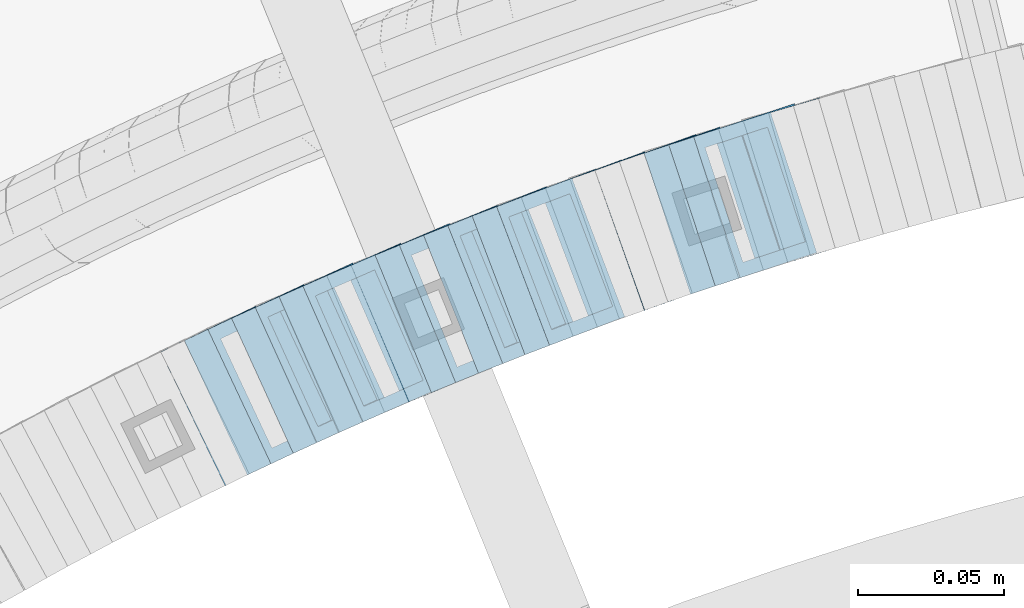
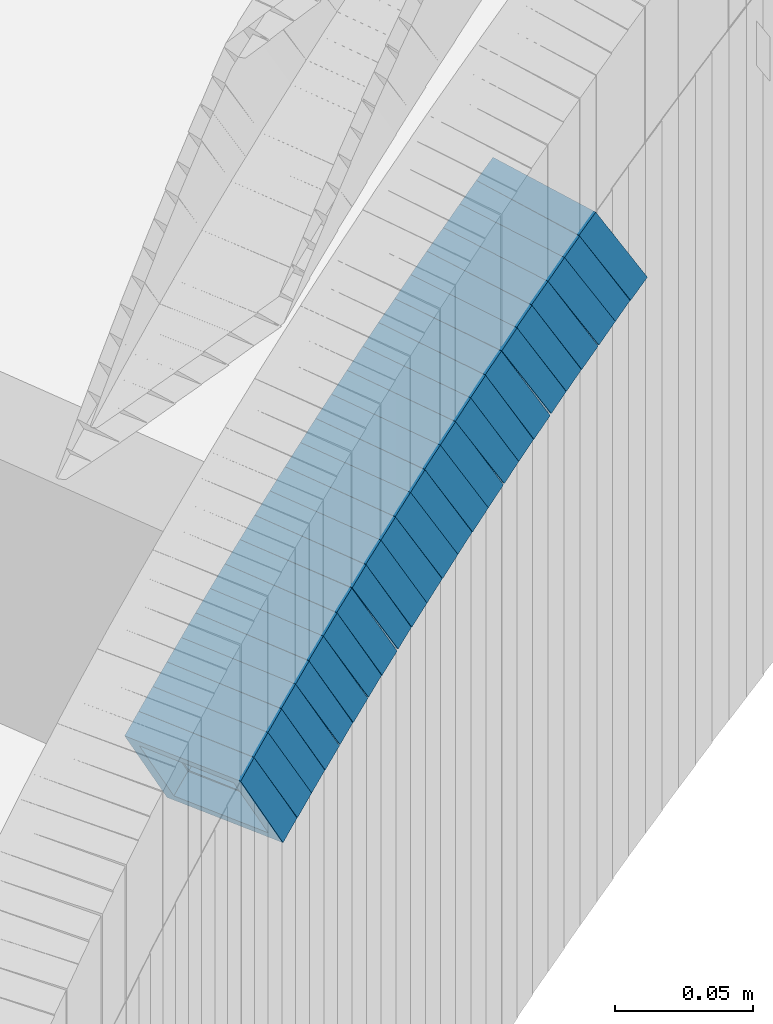
# One storey, part 747 of 975: 24 members.
"""IFC2X3 building model written with IfcOpenShell, lengths in millimetres."""

import ifcopenshell
import ifcopenshell.guid

model = None  # the IFC model being written
_history = None  # IfcOwnerHistory: only IFC2X3 demands one
_inside = {}  # id of a spatial element -> (the spatial element, [elements in it])
_under = {}  # id of a project, library or spatial element -> (it, [spatial elements below it])
_declared = {}  # id of a project -> (the project, [libraries it declares])
_typed = {}  # id of a type object -> (the type object, [elements of that type])
_made_of = {}  # id of a material, layer set ... -> (it, [elements and type objects made of it])


def new_model(schema):
    """Start an empty IFC model of exactly this schema.

    Asked for "IFC4X3", IfcOpenShell would pick the latest addendum, in which some entities
    have other attributes; the version numbers below select the first issue.
    IFC2X3 requires an IfcOwnerHistory on every rooted entity: one is made here for all.
    """
    global model, _history
    if schema == "IFC4X3":
        model = ifcopenshell.file(schema_version=(4, 3, 0, 0))
    else:
        model = ifcopenshell.file(schema=schema)
    _inside.clear()
    _under.clear()
    _declared.clear()
    _typed.clear()
    _made_of.clear()
    _history = None
    if model.schema == "IFC2X3":
        org = make("IfcOrganization", Name="unknown")
        user = make(
            "IfcPersonAndOrganization",
            ThePerson=make("IfcPerson", FamilyName="unknown"),
            TheOrganization=org,
        )
        app = make(
            "IfcApplication",
            ApplicationDeveloper=org,
            Version="unknown",
            ApplicationFullName="unknown",
            ApplicationIdentifier="unknown",
        )
        _history = make(
            "IfcOwnerHistory",
            OwningUser=user,
            OwningApplication=app,
            ChangeAction="ADDED",
            CreationDate=0,
        )
    return model


def make(cls, **values):
    """One entity of the class cls with the attributes given. An attribute that is None is left unset."""
    return model.create_entity(
        cls, **{name: value for name, value in values.items() if value is not None}
    )


def rooted(cls, **values):
    """An entity with a GlobalId (a new one), such as an element, a storey or a relation."""
    return make(cls, GlobalId=ifcopenshell.guid.new(), OwnerHistory=_history, **values)


def si_unit(unit_type, name, prefix=None):
    """IfcSIUnit, for example si_unit("LENGTHUNIT", "METRE", prefix="MILLI")."""
    return make("IfcSIUnit", UnitType=unit_type, Prefix=prefix, Name=name)


def assignment(units):
    """IfcUnitAssignment: the units of a project."""
    return None if units is None else make("IfcUnitAssignment", Units=units)


def point(xyz):
    """IfcCartesianPoint."""
    return None if xyz is None else make("IfcCartesianPoint", Coordinates=xyz)


def direction(xyz):
    """IfcDirection."""
    return None if xyz is None else make("IfcDirection", DirectionRatios=xyz)


def frame(location, z_axis=None, x_axis=None):
    """IfcAxis2Placement3D, a coordinate frame: its origin and axes. An axis left out is left unset."""
    return make(
        "IfcAxis2Placement3D",
        Location=point(location),
        Axis=direction(z_axis),
        RefDirection=direction(x_axis),
    )


def origin_with_axes():
    """The frame at (0, 0, 0) with the z axis (0, 0, 1) and the x axis (1, 0, 0) written out."""
    return frame((0.0, 0.0, 0.0), z_axis=(0.0, 0.0, 1.0), x_axis=(1.0, 0.0, 0.0))


def place(relative_to, where):
    """IfcLocalPlacement: puts the frame where relative to a parent placement (None: the world)."""
    return make(
        "IfcLocalPlacement", PlacementRelTo=relative_to, RelativePlacement=where
    )


def context(
    kind, dimensions, precision=None, world=None, true_north=None, identifier=None
):
    """IfcGeometricRepresentationContext, for example the 3D "Model" context."""
    return make(
        "IfcGeometricRepresentationContext",
        ContextIdentifier=identifier,
        ContextType=kind,
        CoordinateSpaceDimension=dimensions,
        Precision=precision,
        WorldCoordinateSystem=world,
        TrueNorth=true_north,
    )


def subcontext(parent, identifier, kind, view, scale=None):
    """IfcGeometricRepresentationSubContext, for example "Body" below "Model"."""
    return make(
        "IfcGeometricRepresentationSubContext",
        ContextIdentifier=identifier,
        ContextType=kind,
        ParentContext=parent,
        TargetScale=scale,
        TargetView=view,
    )


def project(units=None, contexts=None):
    """IfcProject with its units and contexts."""
    return rooted(
        "IfcProject",
        Name="project",
        RepresentationContexts=contexts,
        UnitsInContext=assignment(units),
    )


def spatial(cls, under=None, at=None, **own):
    """A site, building, storey or space (cls), placed at a placement, below another one or the project."""
    s = rooted(cls, ObjectPlacement=at, **own)
    if under is not None:
        _under.setdefault(under.id(), (under, []))[1].append(s)
    return s


def faces_of(points, faces, orient=None, outer=None):
    """IfcFace entities. A face is a list of loops; a loop is a list of indices into points, from 0.

    orient and outer hold one flag for each loop. By default every Orientation is true, the
    first loop of a face is its IfcFaceOuterBound and the others are IfcFaceBound.
    """
    made = []
    for i, loops in enumerate(faces):
        bounds = []
        for j, loop in enumerate(loops):
            is_outer = j == 0 if outer is None else outer[i][j]
            bounds.append(
                make(
                    "IfcFaceOuterBound" if is_outer else "IfcFaceBound",
                    Bound=make("IfcPolyLoop", Polygon=[points[k] for k in loop]),
                    Orientation=True if orient is None else orient[i][j],
                )
            )
        made.append(make("IfcFace", Bounds=bounds))
    return made


def faceted_brep(points, faces, orient=None, outer=None, voids=None):
    """IfcFacetedBrep: a solid bounded by flat faces; with voids (closed shells), ...WithVoids."""
    shared = [point(p) for p in points]
    hull = make("IfcClosedShell", CfsFaces=faces_of(shared, faces, orient, outer))
    if voids is None:
        return make("IfcFacetedBrep", Outer=hull)
    return make(
        "IfcFacetedBrepWithVoids",
        Outer=hull,
        Voids=[
            make(cls, CfsFaces=faces_of(shared, fs, o, b)) for cls, fs, o, b in voids
        ],
    )


def shape(context_of_items, identifier, shape_type, items):
    """IfcShapeRepresentation: the items that make up one representation, for example the "Body"."""
    return make(
        "IfcShapeRepresentation",
        ContextOfItems=context_of_items,
        RepresentationIdentifier=identifier,
        RepresentationType=shape_type,
        Items=items,
    )


def material(Name=None, Category=None):
    """IfcMaterial."""
    return make("IfcMaterial", Name=Name, Category=Category)


def made_of(thing, what):
    """Note that an element or type object is made of a material, layer set ...; save() writes the relation."""
    if what is not None:
        _made_of.setdefault(what.id(), (what, []))[1].append(thing)
    return thing


def type_object(cls, material=None, **own):
    """A type object (cls), such as IfcWallType, which elements share."""
    return made_of(rooted(cls, **own), material)


def element(
    cls,
    number,
    at=None,
    inside=None,
    cuts=None,
    type_object=None,
    material=None,
    context=None,
    identifier="Body",
    shape_type=None,
    held_by="IfcProductDefinitionShape",
    body=None,
    shapes=None,
    **own,
):
    """One element of the class cls, such as IfcWall. Its Tag is "e" and its number.

    at: its placement. inside: the storey or other place that contains it. cuts: it is an
    opening in that element (IfcRelVoidsElement). A single representation is given by context,
    identifier, shape_type and body (its items); several are given by shapes. held_by: the class
    of the entity that holds the representations. save() writes the other relations.
    """
    e = rooted(cls, Tag="e%d" % number, ObjectPlacement=at, **own)
    if body is not None:
        shapes = [shape(context, identifier, shape_type, body)]
    if shapes is not None:
        e.Representation = make(held_by, Representations=shapes)
    if inside is not None:
        _inside.setdefault(inside.id(), (inside, []))[1].append(e)
    if cuts is not None:
        rooted(
            "IfcRelVoidsElement", RelatingBuildingElement=cuts, RelatedOpeningElement=e
        )
    if type_object is not None:
        _typed.setdefault(type_object.id(), (type_object, []))[1].append(e)
    return made_of(e, material)


def aggregate(whole, parts):
    """IfcRelAggregates: a whole, such as a stair, and the parts it consists of."""
    return rooted("IfcRelAggregates", RelatingObject=whole, RelatedObjects=parts)


def save(model, path):
    """Write the relations noted so far, then the file.

    IfcRelAggregates (storeys below a building ...), IfcRelContainedInSpatialStructure (elements
    in a storey), IfcRelDefinesByType, IfcRelAssociatesMaterial and IfcRelDeclares: one each for
    every whole, place, type object, material and project.
    """
    for whole, parts in _under.values():
        aggregate(whole, parts)
    for where, things in _inside.values():
        rooted(
            "IfcRelContainedInSpatialStructure",
            RelatedElements=things,
            RelatingStructure=where,
        )
    for kind, things in _typed.values():
        rooted("IfcRelDefinesByType", RelatedObjects=things, RelatingType=kind)
    for what, things in _made_of.values():
        rooted("IfcRelAssociatesMaterial", RelatedObjects=things, RelatingMaterial=what)
    for by, libraries in _declared.values():
        rooted("IfcRelDeclares", RelatingContext=by, RelatedDefinitions=libraries)
    model.write(path)


model = new_model("IFC2X3")

# Units and contexts
model_context = context("Model", 3, precision=1e-05, world=origin_with_axes())
body_context = subcontext(model_context, "Body", "Model", "MODEL_VIEW")
ifc_project = project(units=[si_unit("LENGTHUNIT", "METRE", prefix="MILLI"), si_unit("AREAUNIT", "SQUARE_METRE"), si_unit("VOLUMEUNIT", "CUBIC_METRE"), si_unit("MASSUNIT", "GRAM", prefix="KILO"), si_unit("TIMEUNIT", "SECOND"), si_unit("PLANEANGLEUNIT", "RADIAN"), si_unit("SOLIDANGLEUNIT", "STERADIAN"), si_unit("THERMODYNAMICTEMPERATUREUNIT", "DEGREE_CELSIUS"), si_unit("LUMINOUSINTENSITYUNIT", "LUMEN")], contexts=[model_context])

# Site, building, storey
site_placement = place(None, origin_with_axes())
site = spatial("IfcSite", under=ifc_project, at=site_placement, CompositionType="ELEMENT")
building_placement = place(site_placement, origin_with_axes())
building = spatial("IfcBuilding", under=site, at=building_placement, Name="Undefined", CompositionType="ELEMENT")
storey_placement = place(building_placement, origin_with_axes())
storey = spatial("IfcBuildingStorey", under=building, at=storey_placement, Name="Undefined", CompositionType="ELEMENT", Elevation=0.0)

# Members
ifc_material = material()
member_type = type_object("IfcMemberType", Name="HSS2X2X.188_TUBES", PredefinedType="NOTDEFINED")
member_1_placement = place(storey_placement, frame((34323.8165728446, 4738.97898796825, 764.418542144126), z_axis=(-0.292504341712513, 0.956264194707367, 1.21399807540002e-10), x_axis=(0.804973330447488, 0.246227136136992, 0.539805645300284)))
element("IfcMember", 1, at=member_1_placement, inside=storey, type_object=member_type, material=ifc_material, Name="WALL", ObjectType="HSS2X2X.188_TUBES", context=body_context, shape_type="Brep", body=[
    faceted_brep([(0.0, 20.6374999999753, -20.6375000000298), (0.0, -20.6375000000153, -20.6375000000153), (10.5550935571373, -20.6374999999935, -20.6374999999753), (10.5550935571373, 20.6375000000025, -20.6374999999862), (0.0, -20.6374999999825, 20.6375000000335), (10.5550935571027, -20.6374999999989, 20.6374999999862), (0.0, 20.6375000000116, 20.6375000000189), (10.5550935571027, 20.6374999999953, 20.6374999999716), (0.0, 25.3999999999724, -25.4000000000342), (0.0, 25.400000000016, 25.4000000000196), (10.5550935570991, 25.3999999999924, 25.3999999999651), (10.5550935571373, 25.3999999999996, -25.3999999999905), (0.0, -25.399999999976, 25.4000000000378), (10.5550935571009, -25.3999999999996, 25.3999999999833), (0.0, -25.400000000016, -25.4000000000196), (10.5550935571428, -25.3999999999905, -25.3999999999724)], [[[0, 1, 2, 3]], [[1, 4, 5, 2]], [[4, 6, 7, 5]], [[6, 0, 3, 7]], [[8, 9, 10, 11]], [[9, 12, 13, 10]], [[12, 14, 15, 13]], [[14, 8, 11, 15]], [[13, 15, 11, 10], [5, 7, 3, 2]], [[14, 12, 9, 8], [6, 4, 1, 0]]]),
])
for number, where, z_axis, x_axis, name in (
    (2, (34315.6826337689, 4736.60196878337, 758.67641036443), (-0.312873574961078, 0.949794781040133, -1.60484887601342e-11), (0.801102899019765, 0.263892720006465, 0.537210180013109), "WALL"),
    (3, (34298.6826337689, 4731.00196878336, 747.176410364466), (-0.312873574961078, 0.949794781040133, -1.60484887601342e-11), (0.801102899019765, 0.263892720006465, 0.537210180013109), "WALL"),
):
    element("IfcMember", number, at=place(storey_placement, frame(where, z_axis=z_axis, x_axis=x_axis)), inside=storey, type_object=member_type, material=ifc_material, Name=name, ObjectType="HSS2X2X.188_TUBES", context=body_context, shape_type="Brep", body=[
        faceted_brep([(0.0, 20.6374999999753, -20.6375000000298), (0.0, -20.6375000000153, -20.6375000000153), (10.6061303028146, -20.6374999999571, -20.6374999999643), (10.6061303027491, 20.6374999999971, -20.6375000000007), (0.0, -20.6374999999825, 20.6375000000335), (10.6061303027855, -20.6374999999825, 20.6375000000116), (0.0, 20.6375000000116, 20.6375000000189), (10.6061303027236, 20.637499999968, 20.6374999999716), (0.0, 25.3999999999724, -25.4000000000342), (0.0, 25.400000000016, 25.4000000000196), (10.6061303027163, 25.3999999999651, 25.3999999999651), (10.6061303027454, 25.3999999999942, -25.4000000000051), (0.0, -25.399999999976, 25.4000000000378), (10.6061303027891, -25.3999999999796, 25.4000000000124), (0.0, -25.400000000016, -25.4000000000196), (10.6061303028182, -25.3999999999505, -25.3999999999542)], [[[0, 1, 2, 3]], [[1, 4, 5, 2]], [[4, 6, 7, 5]], [[6, 0, 3, 7]], [[8, 9, 10, 11]], [[9, 12, 13, 10]], [[12, 14, 15, 13]], [[14, 8, 11, 15]], [[13, 15, 11, 10], [5, 7, 3, 2]], [[14, 12, 9, 8], [6, 4, 1, 0]]]),
    ])
member_2_placement = place(storey_placement, frame((34307.3431606508, 4733.85484822681, 752.984999679499), z_axis=(-0.312873574961078, 0.949794781040133, -1.60484887601342e-11), x_axis=(0.797042365334205, 0.262555132110077, 0.543864202228016)))
element("IfcMember", 4, at=member_2_placement, inside=storey, type_object=member_type, material=ifc_material, Name="WALL", ObjectType="HSS2X2X.188_TUBES", context=body_context, shape_type="Brep", body=[
    faceted_brep([(0.0, 20.6374999999753, -20.6375000000298), (0.0, -20.6375000000153, -20.6375000000153), (10.6625512894789, -20.6374999999625, -20.6374999999389), (10.6625512893879, 20.6374999999789, -20.6375000000371), (0.0, -20.6374999999825, 20.6375000000335), (10.6625512894352, -20.6374999999989, 20.6375000000153), (0.0, 20.6375000000116, 20.6375000000189), (10.6625512893443, 20.6374999999443, 20.6374999999134), (0.0, 25.3999999999724, -25.4000000000342), (0.0, 25.400000000016, 25.4000000000196), (10.6625512893297, 25.3999999999342, 25.3999999998996), (10.6625512893916, 25.399999999976, -25.4000000000415), (0.0, -25.399999999976, 25.4000000000378), (10.6625512894389, -25.399999999996, 25.400000000016), (0.0, -25.400000000016, -25.4000000000196), (10.6625512894971, -25.3999999999523, -25.3999999999214)], [[[0, 1, 2, 3]], [[1, 4, 5, 2]], [[4, 6, 7, 5]], [[6, 0, 3, 7]], [[8, 9, 10, 11]], [[9, 12, 13, 10]], [[12, 14, 15, 13]], [[14, 8, 11, 15]], [[13, 15, 11, 10], [5, 7, 3, 2]], [[14, 12, 9, 8], [6, 4, 1, 0]]]),
])
member_3_placement = place(storey_placement, frame((34290.6272887781, 4728.42335470334, 741.520119871507), z_axis=(-0.326337459514733, 0.945253332455099, 3.89483261642454e-10), x_axis=(0.795645785953015, 0.274687234983708, 0.539902496967939)))
element("IfcMember", 5, at=member_3_placement, inside=storey, type_object=member_type, material=ifc_material, Name="WALL", ObjectType="HSS2X2X.188_TUBES", context=body_context, shape_type="Brep", body=[
    faceted_brep([(0.0, 20.6374999999753, -20.6375000000298), (0.0, -20.6375000000153, -20.6375000000153), (10.5550935571373, -20.6374999999935, -20.6374999999753), (10.5550935571373, 20.6375000000025, -20.6374999999862), (0.0, -20.6374999999825, 20.6375000000335), (10.5550935571027, -20.6374999999989, 20.6374999999862), (0.0, 20.6375000000116, 20.6375000000189), (10.5550935571027, 20.6374999999953, 20.6374999999716), (0.0, 25.3999999999724, -25.4000000000342), (0.0, 25.400000000016, 25.4000000000196), (10.5550935570991, 25.3999999999924, 25.3999999999651), (10.5550935571373, 25.3999999999996, -25.3999999999905), (0.0, -25.399999999976, 25.4000000000378), (10.5550935571009, -25.3999999999996, 25.3999999999833), (0.0, -25.400000000016, -25.4000000000196), (10.5550935571428, -25.3999999999905, -25.3999999999724)], [[[0, 1, 2, 3]], [[1, 4, 5, 2]], [[4, 6, 7, 5]], [[6, 0, 3, 7]], [[8, 9, 10, 11]], [[9, 12, 13, 10]], [[12, 14, 15, 13]], [[14, 8, 11, 15]], [[13, 15, 11, 10], [5, 7, 3, 2]], [[14, 12, 9, 8], [6, 4, 1, 0]]]),
])
member_4_placement = place(storey_placement, frame((34273.7306456526, 4722.52375767464, 729.932138284869), z_axis=(-0.332820118030279, 0.942990333478722, -1.27761950352578e-10), x_axis=(0.797007326545317, 0.281296703839518, 0.534463736695119)))
element("IfcMember", 6, at=member_4_placement, inside=storey, type_object=member_type, material=ifc_material, Name="WALL", ObjectType="HSS2X2X.188_TUBES", context=body_context, shape_type="Brep", body=[
    faceted_brep([(0.0, 20.6374999999753, -20.6375000000298), (0.0, -20.6375000000153, -20.6375000000153), (10.6625512894789, -20.6374999999625, -20.6374999999389), (10.6625512893879, 20.6374999999789, -20.6375000000371), (0.0, -20.6374999999825, 20.6375000000335), (10.6625512894352, -20.6374999999989, 20.6375000000153), (0.0, 20.6375000000116, 20.6375000000189), (10.6625512893443, 20.6374999999443, 20.6374999999134), (0.0, 25.3999999999724, -25.4000000000342), (0.0, 25.400000000016, 25.4000000000196), (10.6625512893297, 25.3999999999342, 25.3999999998996), (10.6625512893916, 25.399999999976, -25.4000000000415), (0.0, -25.399999999976, 25.4000000000378), (10.6625512894389, -25.399999999996, 25.400000000016), (0.0, -25.400000000016, -25.4000000000196), (10.6625512894971, -25.3999999999523, -25.3999999999214)], [[[0, 1, 2, 3]], [[1, 4, 5, 2]], [[4, 6, 7, 5]], [[6, 0, 3, 7]], [[8, 9, 10, 11]], [[9, 12, 13, 10]], [[12, 14, 15, 13]], [[14, 8, 11, 15]], [[13, 15, 11, 10], [5, 7, 3, 2]], [[14, 12, 9, 8], [6, 4, 1, 0]]]),
])
member_5_placement = place(storey_placement, frame((34265.6662966082, 4719.75106608921, 724.273324885295), z_axis=(-0.346222870288242, 0.938152292588667, 1.33710273075849e-10), x_axis=(0.791397023826104, 0.292063186935858, 0.537019408882077)))
element("IfcMember", 7, at=member_5_placement, inside=storey, type_object=member_type, material=ifc_material, Name="WALL", ObjectType="HSS2X2X.188_TUBES", context=body_context, shape_type="Brep", body=[
    faceted_brep([(0.0, 20.6374999999753, -20.6375000000298), (0.0, -20.6375000000153, -20.6375000000153), (10.6061303028146, -20.6374999999571, -20.6374999999643), (10.6061303027491, 20.6374999999971, -20.6375000000007), (0.0, -20.6374999999825, 20.6375000000335), (10.6061303027855, -20.6374999999825, 20.6375000000116), (0.0, 20.6375000000116, 20.6375000000189), (10.6061303027236, 20.637499999968, 20.6374999999716), (0.0, 25.3999999999724, -25.4000000000342), (0.0, 25.400000000016, 25.4000000000196), (10.6061303027163, 25.3999999999651, 25.3999999999651), (10.6061303027454, 25.3999999999942, -25.4000000000051), (0.0, -25.399999999976, 25.4000000000378), (10.6061303027891, -25.3999999999796, 25.4000000000124), (0.0, -25.400000000016, -25.4000000000196), (10.6061303028182, -25.3999999999505, -25.3999999999542)], [[[0, 1, 2, 3]], [[1, 4, 5, 2]], [[4, 6, 7, 5]], [[6, 0, 3, 7]], [[8, 9, 10, 11]], [[9, 12, 13, 10]], [[12, 14, 15, 13]], [[14, 8, 11, 15]], [[13, 15, 11, 10], [5, 7, 3, 2]], [[14, 12, 9, 8], [6, 4, 1, 0]]]),
])
for number, where, z_axis, x_axis, name in (
    (8, (34282.5582919997, 4725.69437407912, 735.805968604175), (-0.336336397332197, 0.941741911475537, -3.18128854814859e-10), (0.789507159090374, 0.28196684303219, 0.545135896062172), "WALL"),
    (9, (34249.1290401391, 4713.6639245659, 712.749194341532), (-0.35599532744167, 0.934487734986232, 3.27740508510033e-10), (0.789193496498159, 0.300645141189924, 0.535524158338259), "WALL"),
):
    element("IfcMember", number, at=place(storey_placement, frame(where, z_axis=z_axis, x_axis=x_axis)), inside=storey, type_object=member_type, material=ifc_material, Name=name, ObjectType="HSS2X2X.188_TUBES", context=body_context, shape_type="Brep", body=[
        faceted_brep([(0.0, 20.6374999999753, -20.6375000000298), (0.0, -20.6375000000153, -20.6375000000153), (10.6395488625676, -20.6374999999771, -20.6374999999716), (10.6395488625531, 20.6374999999916, -20.6375000000189), (0.0, -20.6374999999825, 20.6375000000335), (10.6395488625731, -20.6374999999844, 20.6375000000153), (0.0, 20.6375000000116, 20.6375000000189), (10.6395488625585, 20.6374999999825, 20.637499999968), (0.0, 25.3999999999724, -25.4000000000342), (0.0, 25.400000000016, 25.4000000000196), (10.6395488625567, 25.3999999999778, 25.3999999999614), (10.6395488625494, 25.3999999999887, -25.4000000000233), (0.0, -25.399999999976, 25.4000000000378), (10.6395488625749, -25.3999999999851, 25.400000000016), (0.0, -25.400000000016, -25.4000000000196), (10.6395488625658, -25.399999999976, -25.3999999999687)], [[[0, 1, 2, 3]], [[1, 4, 5, 2]], [[4, 6, 7, 5]], [[6, 0, 3, 7]], [[8, 9, 10, 11]], [[9, 12, 13, 10]], [[12, 14, 15, 13]], [[14, 8, 11, 15]], [[13, 15, 11, 10], [5, 7, 3, 2]], [[14, 12, 9, 8], [6, 4, 1, 0]]]),
    ])
member_6_placement = place(storey_placement, frame((34240.8868920213, 4710.52405861628, 707.057245340871), z_axis=(-0.35599532744167, 0.934487734986232, 3.27740508510033e-10), x_axis=(0.785218207651455, 0.299130745867308, 0.542174476759562)))
element("IfcMember", 10, at=member_6_placement, inside=storey, type_object=member_type, material=ifc_material, Name="WALL", ObjectType="HSS2X2X.188_TUBES", context=body_context, shape_type="Brep", body=[
    faceted_brep([(0.0, 20.6374999999753, -20.6375000000298), (0.0, -20.6375000000153, -20.6375000000153), (10.6985980389491, -20.6375000000317, -20.6375000000698), (10.6985980389982, 20.6375000000116, -20.6374999999643), (0.0, -20.6374999999825, 20.6375000000335), (10.6985980389818, -20.6374999999989, 20.6374999999789), (0.0, 20.6375000000116, 20.6375000000189), (10.6985980390309, 20.6375000000407, 20.6375000000808), (0.0, 25.3999999999724, -25.4000000000342), (0.0, 25.400000000016, 25.4000000000196), (10.6985980390382, 25.4000000000487, 25.4000000000997), (10.6985980390036, 25.4000000000142, -25.3999999999542), (0.0, -25.399999999976, 25.4000000000378), (10.6985980389763, -25.4000000000033, 25.3999999999724), (0.0, -25.400000000016, -25.4000000000196), (10.6985980389418, -25.400000000036, -25.4000000000851)], [[[0, 1, 2, 3]], [[1, 4, 5, 2]], [[4, 6, 7, 5]], [[6, 0, 3, 7]], [[8, 9, 10, 11]], [[9, 12, 13, 10]], [[12, 14, 15, 13]], [[14, 8, 11, 15]], [[13, 15, 11, 10], [5, 7, 3, 2]], [[14, 12, 9, 8], [6, 4, 1, 0]]]),
])
member_7_placement = place(storey_placement, frame((34232.7570316657, 4707.50296642698, 701.288412355782), z_axis=(-0.369459572891712, 0.929246804674987, -1.24138068713364e-11), x_axis=(0.783332654127572, 0.311445513050761, 0.53795134108765)))
element("IfcMember", 11, at=member_7_placement, inside=storey, type_object=member_type, material=ifc_material, Name="WALL", ObjectType="HSS2X2X.188_TUBES", context=body_context, shape_type="Brep", body=[
    faceted_brep([(0.0, 20.6374999999753, -20.6375000000298), (0.0, -20.6375000000153, -20.6375000000153), (10.6004716875832, -20.6375000000153, -20.6375000000553), (10.6004716875814, 20.6374999999898, -20.6375000000444), (0.0, -20.6374999999825, 20.6375000000335), (10.6004716876068, -20.6375000000044, 20.6374999999862), (0.0, 20.6375000000116, 20.6375000000189), (10.6004716876032, 20.6374999999989, 20.6374999999971), (0.0, 25.3999999999724, -25.4000000000342), (0.0, 25.400000000016, 25.4000000000196), (10.600471687605, 25.4000000000015, 25.4000000000051), (10.6004716875814, 25.3999999999869, -25.4000000000487), (0.0, -25.399999999976, 25.4000000000378), (10.6004716876068, -25.4000000000015, 25.3999999999905), (0.0, -25.400000000016, -25.4000000000196), (10.6004716875814, -25.4000000000178, -25.4000000000669)], [[[0, 1, 2, 3]], [[1, 4, 5, 2]], [[4, 6, 7, 5]], [[6, 0, 3, 7]], [[8, 9, 10, 11]], [[9, 12, 13, 10]], [[12, 14, 15, 13]], [[14, 8, 11, 15]], [[13, 15, 11, 10], [5, 7, 3, 2]], [[14, 12, 9, 8], [6, 4, 1, 0]]]),
])
member_8_placement = place(storey_placement, frame((34257.6950830296, 4716.83055739184, 718.648564623412), z_axis=(-0.349886241383174, 0.936792195788775, 3.29886347572028e-10), x_axis=(0.783786568187518, 0.292739561070065, 0.547706276131047)))
element("IfcMember", 12, at=member_8_placement, inside=storey, type_object=member_type, material=ifc_material, Name="WALL", ObjectType="HSS2X2X.188_TUBES", context=body_context, shape_type="Brep", body=[
    faceted_brep([(0.0, 20.6374999999753, -20.6375000000298), (0.0, -20.6375000000153, -20.6375000000153), (10.5948100501191, -20.6375000000335, -20.6375000000844), (10.5948100501555, 20.6374999999971, -20.6375000000116), (0.0, -20.6374999999825, 20.6375000000335), (10.5948100501446, -20.6375000000098, 20.6374999999571), (0.0, 20.6375000000116, 20.6375000000189), (10.5948100501828, 20.6375000000189, 20.6375000000298), (0.0, 25.3999999999724, -25.4000000000342), (0.0, 25.400000000016, 25.4000000000196), (10.5948100501919, 25.4000000000251, 25.4000000000451), (10.5948100501591, 25.3999999999978, -25.4000000000051), (0.0, -25.399999999976, 25.4000000000378), (10.5948100501482, -25.4000000000106, 25.3999999999578), (0.0, -25.400000000016, -25.4000000000196), (10.5948100501118, -25.4000000000378, -25.400000000096)], [[[0, 1, 2, 3]], [[1, 4, 5, 2]], [[4, 6, 7, 5]], [[6, 0, 3, 7]], [[8, 9, 10, 11]], [[9, 12, 13, 10]], [[12, 14, 15, 13]], [[14, 8, 11, 15]], [[13, 15, 11, 10], [5, 7, 3, 2]], [[14, 12, 9, 8], [6, 4, 1, 0]]]),
])
for number, where, z_axis, x_axis, name in (
    (13, (34216.3105150226, 4701.01734426549, 689.762563608194), (-0.379066925583975, 0.925369259230235, -2.87953753286274e-10), (0.78100569470663, 0.319930043879709, 0.536353308798354), "WALL"),
    (14, (34208.0105150226, 4697.61734426547, 684.062563608211), (-0.379066925583975, 0.925369259230235, -2.87953753286274e-10), (0.78100569470663, 0.319930043879709, 0.536353308798354), "WALL"),
):
    element("IfcMember", number, at=place(storey_placement, frame(where, z_axis=z_axis, x_axis=x_axis)), inside=storey, type_object=member_type, material=ifc_material, Name=name, ObjectType="HSS2X2X.188_TUBES", context=body_context, shape_type="Brep", body=[
        faceted_brep([(0.0, 20.6374999999753, -20.6375000000298), (0.0, -20.6375000000153, -20.6375000000153), (10.6348483769107, -20.637499999988, -20.6374999999825), (10.6348483768415, 20.6374999999734, -20.6375000001026), (0.0, -20.6374999999825, 20.6375000000335), (10.6348483769852, -20.6374999999589, 20.6375000001462), (0.0, 20.6375000000116, 20.6375000000189), (10.6348483769161, 20.6375000000044, 20.6375000000226), (0.0, 25.3999999999724, -25.4000000000342), (0.0, 25.400000000016, 25.4000000000196), (10.6348483769179, 25.4000000000015, 25.4000000000233), (10.6348483768288, 25.3999999999669, -25.4000000001324), (0.0, -25.399999999976, 25.4000000000378), (10.6348483769998, -25.3999999999505, 25.4000000001688), (0.0, -25.400000000016, -25.4000000000196), (10.6348483769107, -25.3999999999887, -25.3999999999833)], [[[0, 1, 2, 3]], [[1, 4, 5, 2]], [[4, 6, 7, 5]], [[6, 0, 3, 7]], [[8, 9, 10, 11]], [[9, 12, 13, 10]], [[12, 14, 15, 13]], [[14, 8, 11, 15]], [[13, 15, 11, 10], [5, 7, 3, 2]], [[14, 12, 9, 8], [6, 4, 1, 0]]]),
    ])
member_9_placement = place(storey_placement, frame((34200.2855753788, 4694.53387528469, 678.408754326344), z_axis=(-0.392565197996758, 0.919724178937232, -1.40913698487566e-11), x_axis=(0.770947774111817, 0.329063074047664, 0.545304523078927)))
element("IfcMember", 15, at=member_9_placement, inside=storey, type_object=member_type, material=ifc_material, Name="WALL", ObjectType="HSS2X2X.188_TUBES", context=body_context, shape_type="Brep", body=[
    faceted_brep([(0.0, 20.6374999999753, -20.6375000000298), (0.0, -20.6375000000153, -20.6375000000153), (10.6395488625676, -20.6374999999771, -20.6374999999716), (10.6395488625531, 20.6374999999916, -20.6375000000189), (0.0, -20.6374999999825, 20.6375000000335), (10.6395488625731, -20.6374999999844, 20.6375000000153), (0.0, 20.6375000000116, 20.6375000000189), (10.6395488625585, 20.6374999999825, 20.637499999968), (0.0, 25.3999999999724, -25.4000000000342), (0.0, 25.400000000016, 25.4000000000196), (10.6395488625567, 25.3999999999778, 25.3999999999614), (10.6395488625494, 25.3999999999887, -25.4000000000233), (0.0, -25.399999999976, 25.4000000000378), (10.6395488625749, -25.3999999999851, 25.400000000016), (0.0, -25.400000000016, -25.4000000000196), (10.6395488625658, -25.399999999976, -25.3999999999687)], [[[0, 1, 2, 3]], [[1, 4, 5, 2]], [[4, 6, 7, 5]], [[6, 0, 3, 7]], [[8, 9, 10, 11]], [[9, 12, 13, 10]], [[12, 14, 15, 13]], [[14, 8, 11, 15]], [[13, 15, 11, 10], [5, 7, 3, 2]], [[14, 12, 9, 8], [6, 4, 1, 0]]]),
])
member_10_placement = place(storey_placement, frame((34224.614122922, 4704.26542439634, 695.597238224744), z_axis=(-0.369459572891712, 0.929246804674987, -1.24138068713364e-11), x_axis=(0.779351312004608, 0.30986257000168, 0.544606941003005)))
element("IfcMember", 16, at=member_10_placement, inside=storey, type_object=member_type, material=ifc_material, Name="WALL", ObjectType="HSS2X2X.188_TUBES", context=body_context, shape_type="Brep", body=[
    faceted_brep([(0.0, 20.6374999999753, -20.6375000000298), (0.0, -20.6375000000153, -20.6375000000153), (10.648004507897, -20.6374999999862, -20.637499999968), (10.6480045078188, 20.6374999999771, -20.6375000000808), (0.0, -20.6374999999825, 20.6375000000335), (10.6480045079406, -20.6374999999698, 20.6375000001062), (0.0, 20.6375000000116, 20.6375000000189), (10.6480045078679, 20.6374999999935, 20.6375000000007), (0.0, 25.3999999999724, -25.4000000000342), (0.0, 25.400000000016, 25.4000000000196), (10.6480045078661, 25.3999999999905, 25.4000000000015), (10.648004507806, 25.3999999999705, -25.4000000000997), (0.0, -25.399999999976, 25.4000000000378), (10.6480045079552, -25.3999999999633, 25.4000000001288), (0.0, -25.400000000016, -25.4000000000196), (10.6480045078988, -25.3999999999814, -25.3999999999651)], [[[0, 1, 2, 3]], [[1, 4, 5, 2]], [[4, 6, 7, 5]], [[6, 0, 3, 7]], [[8, 9, 10, 11]], [[9, 12, 13, 10]], [[12, 14, 15, 13]], [[14, 8, 11, 15]], [[13, 15, 11, 10], [5, 7, 3, 2]], [[14, 12, 9, 8], [6, 4, 1, 0]]]),
])
member_11_placement = place(storey_placement, frame((34191.6595799179, 4690.83063570368, 672.536293819157), z_axis=(-0.388553247225798, 0.921426271641029, -2.19913658838777e-10), x_axis=(0.778630818029209, 0.328338297012205, 0.534722369019933)))
element("IfcMember", 17, at=member_11_placement, inside=storey, type_object=member_type, material=ifc_material, Name="WALL", ObjectType="HSS2X2X.188_TUBES", context=body_context, shape_type="Brep", body=[
    faceted_brep([(0.0, 20.6374999999753, -20.6375000000298), (0.0, -20.6375000000153, -20.6375000000153), (10.6625512894789, -20.6374999999625, -20.6374999999389), (10.6625512893879, 20.6374999999789, -20.6375000000371), (0.0, -20.6374999999825, 20.6375000000335), (10.6625512894352, -20.6374999999989, 20.6375000000153), (0.0, 20.6375000000116, 20.6375000000189), (10.6625512893443, 20.6374999999443, 20.6374999999134), (0.0, 25.3999999999724, -25.4000000000342), (0.0, 25.400000000016, 25.4000000000196), (10.6625512893297, 25.3999999999342, 25.3999999998996), (10.6625512893916, 25.399999999976, -25.4000000000415), (0.0, -25.399999999976, 25.4000000000378), (10.6625512894389, -25.399999999996, 25.400000000016), (0.0, -25.400000000016, -25.4000000000196), (10.6625512894971, -25.3999999999523, -25.3999999999214)], [[[0, 1, 2, 3]], [[1, 4, 5, 2]], [[4, 6, 7, 5]], [[6, 0, 3, 7]], [[8, 9, 10, 11]], [[9, 12, 13, 10]], [[12, 14, 15, 13]], [[14, 8, 11, 15]], [[13, 15, 11, 10], [5, 7, 3, 2]], [[14, 12, 9, 8], [6, 4, 1, 0]]]),
])
member_12_placement = place(storey_placement, frame((34183.9288432364, 4687.65066231859, 666.880674673135), z_axis=(-0.401990062304751, 0.915644030072944, -1.61734078574227e-10), x_axis=(0.768539881106517, 0.337407753046784, 0.543601379075423)))
element("IfcMember", 18, at=member_12_placement, inside=storey, type_object=member_type, material=ifc_material, Name="WALL", ObjectType="HSS2X2X.188_TUBES", context=body_context, shape_type="Brep", body=[
    faceted_brep([(0.0, 20.6374999999753, -20.6375000000298), (0.0, -20.6375000000153, -20.6375000000153), (10.6709887076922, -20.6374999999844, -20.6374999999825), (10.6709887076995, 20.6375000000171, -20.6374999999753), (0.0, -20.6374999999825, 20.6375000000335), (10.6709887076922, -20.6374999999971, 20.6375000000153), (0.0, 20.6375000000116, 20.6375000000189), (10.6709887076941, 20.6375000000025, 20.6375000000189), (0.0, 25.3999999999724, -25.4000000000342), (0.0, 25.400000000016, 25.4000000000196), (10.6709887076959, 25.3999999999996, 25.4000000000233), (10.6709887077013, 25.4000000000178, -25.3999999999724), (0.0, -25.399999999976, 25.4000000000378), (10.6709887076904, -25.3999999999978, 25.400000000016), (0.0, -25.400000000016, -25.4000000000196), (10.6709887076959, -25.3999999999796, -25.3999999999796)], [[[0, 1, 2, 3]], [[1, 4, 5, 2]], [[4, 6, 7, 5]], [[6, 0, 3, 7]], [[8, 9, 10, 11]], [[9, 12, 13, 10]], [[12, 14, 15, 13]], [[14, 8, 11, 15]], [[13, 15, 11, 10], [5, 7, 3, 2]], [[14, 12, 9, 8], [6, 4, 1, 0]]]),
])
member_13_placement = place(storey_placement, frame((34175.5741014022, 4683.98272687916, 661.072169074627), z_axis=(-0.401990062304751, 0.915644030072944, -1.61734078574227e-10), x_axis=(0.772451396997992, 0.339125003999019, 0.536947921998508)))
element("IfcMember", 19, at=member_13_placement, inside=storey, type_object=member_type, material=ifc_material, Name="WALL", ObjectType="HSS2X2X.188_TUBES", context=body_context, shape_type="Brep", body=[
    faceted_brep([(0.0, 20.6374999999753, -20.6375000000298), (0.0, -20.6375000000153, -20.6375000000153), (10.6216759506497, -20.637499999968, -20.6374999999534), (10.6216759506497, 20.6375000000262, -20.6374999999643), (0.0, -20.6374999999825, 20.6375000000335), (10.6216759506169, -20.6374999999935, 20.637500000008), (0.0, 20.6375000000116, 20.6375000000189), (10.6216759506242, 20.6375000000007, 20.6374999999971), (0.0, 25.3999999999724, -25.4000000000342), (0.0, 25.400000000016, 25.4000000000196), (10.6216759506169, 25.3999999999978, 25.3999999999869), (10.6216759506533, 25.4000000000269, -25.3999999999614), (0.0, -25.399999999976, 25.4000000000378), (10.6216759506242, -25.3999999999942, 25.4000000000051), (0.0, -25.400000000016, -25.4000000000196), (10.6216759506569, -25.3999999999614, -25.3999999999432)], [[[0, 1, 2, 3]], [[1, 4, 5, 2]], [[4, 6, 7, 5]], [[6, 0, 3, 7]], [[8, 9, 10, 11]], [[9, 12, 13, 10]], [[12, 14, 15, 13]], [[14, 8, 11, 15]], [[13, 15, 11, 10], [5, 7, 3, 2]], [[14, 12, 9, 8], [6, 4, 1, 0]]]),
])
member_14_placement = place(storey_placement, frame((34159.6844583119, 4676.94329615287, 649.607140848199), z_axis=(-0.415494357589276, 0.909595755713204, 1.62858214025619e-10), x_axis=(0.766096610350863, 0.349945365160236, 0.53910502224686)))
element("IfcMember", 20, at=member_14_placement, inside=storey, type_object=member_type, material=ifc_material, Name="WALL", ObjectType="HSS2X2X.188_TUBES", context=body_context, shape_type="Brep", body=[
    faceted_brep([(0.0, 20.6374999999753, -20.6375000000298), (0.0, -20.6375000000153, -20.6375000000153), (10.5744976239494, -20.6375000000207, -20.6375000000335), (10.5744976239657, 20.6375000000098, -20.637500000008), (0.0, -20.6374999999825, 20.6375000000335), (10.5744976239639, -20.6375000000244, 20.6374999999753), (0.0, 20.6375000000116, 20.6375000000189), (10.5744976239803, 20.6374999999989, 20.6374999999935), (0.0, 25.3999999999724, -25.4000000000342), (0.0, 25.400000000016, 25.4000000000196), (10.5744976239857, 25.4000000000051, 25.4000000000015), (10.5744976239675, 25.4000000000124, -25.4000000000051), (0.0, -25.399999999976, 25.4000000000378), (10.5744976239639, -25.4000000000287, 25.3999999999724), (0.0, -25.400000000016, -25.4000000000196), (10.5744976239494, -25.4000000000215, -25.4000000000378)], [[[0, 1, 2, 3]], [[1, 4, 5, 2]], [[4, 6, 7, 5]], [[6, 0, 3, 7]], [[8, 9, 10, 11]], [[9, 12, 13, 10]], [[12, 14, 15, 13]], [[14, 8, 11, 15]], [[13, 15, 11, 10], [5, 7, 3, 2]], [[14, 12, 9, 8], [6, 4, 1, 0]]]),
])
member_15_placement = place(storey_placement, frame((34167.938282813, 4680.71356166568, 655.416334823832), z_axis=(-0.415494357589276, 0.909595755713204, 1.62858214025619e-10), x_axis=(0.762186280713629, 0.348159164869146, 0.545763015794899)))
element("IfcMember", 21, at=member_15_placement, inside=storey, type_object=member_type, material=ifc_material, Name="WALL", ObjectType="HSS2X2X.188_TUBES", context=body_context, shape_type="Brep", body=[
    faceted_brep([(0.0, 20.6374999999753, -20.6375000000298), (0.0, -20.6375000000153, -20.6375000000153), (10.6348483769107, -20.637499999988, -20.6374999999825), (10.6348483768415, 20.6374999999734, -20.6375000001026), (0.0, -20.6374999999825, 20.6375000000335), (10.6348483769852, -20.6374999999589, 20.6375000001462), (0.0, 20.6375000000116, 20.6375000000189), (10.6348483769161, 20.6375000000044, 20.6375000000226), (0.0, 25.3999999999724, -25.4000000000342), (0.0, 25.400000000016, 25.4000000000196), (10.6348483769179, 25.4000000000015, 25.4000000000233), (10.6348483768288, 25.3999999999669, -25.4000000001324), (0.0, -25.399999999976, 25.4000000000378), (10.6348483769998, -25.3999999999505, 25.4000000001688), (0.0, -25.400000000016, -25.4000000000196), (10.6348483769107, -25.3999999999887, -25.3999999999833)], [[[0, 1, 2, 3]], [[1, 4, 5, 2]], [[4, 6, 7, 5]], [[6, 0, 3, 7]], [[8, 9, 10, 11]], [[9, 12, 13, 10]], [[12, 14, 15, 13]], [[14, 8, 11, 15]], [[13, 15, 11, 10], [5, 7, 3, 2]], [[14, 12, 9, 8], [6, 4, 1, 0]]]),
])
member_16_placement = place(storey_placement, frame((34151.7189325499, 4673.35870251109, 643.877954916357), z_axis=(-0.424720211576394, 0.905324661035202, -3.22918367601232e-10), x_axis=(0.763539595237583, 0.358203761111459, 0.537305641167141)))
element("IfcMember", 22, at=member_16_placement, inside=storey, type_object=member_type, material=ifc_material, Name="WALL", ObjectType="HSS2X2X.188_TUBES", context=body_context, shape_type="Brep", body=[
    faceted_brep([(0.0, 20.6374999999753, -20.6375000000298), (0.0, -20.6375000000153, -20.6375000000153), (10.6061303028146, -20.6374999999571, -20.6374999999643), (10.6061303027491, 20.6374999999971, -20.6375000000007), (0.0, -20.6374999999825, 20.6375000000335), (10.6061303027855, -20.6374999999825, 20.6375000000116), (0.0, 20.6375000000116, 20.6375000000189), (10.6061303027236, 20.637499999968, 20.6374999999716), (0.0, 25.3999999999724, -25.4000000000342), (0.0, 25.400000000016, 25.4000000000196), (10.6061303027163, 25.3999999999651, 25.3999999999651), (10.6061303027454, 25.3999999999942, -25.4000000000051), (0.0, -25.399999999976, 25.4000000000378), (10.6061303027891, -25.3999999999796, 25.4000000000124), (0.0, -25.400000000016, -25.4000000000196), (10.6061303028182, -25.3999999999505, -25.3999999999542)], [[[0, 1, 2, 3]], [[1, 4, 5, 2]], [[4, 6, 7, 5]], [[6, 0, 3, 7]], [[8, 9, 10, 11]], [[9, 12, 13, 10]], [[12, 14, 15, 13]], [[14, 8, 11, 15]], [[13, 15, 11, 10], [5, 7, 3, 2]], [[14, 12, 9, 8], [6, 4, 1, 0]]]),
])
member_17_placement = place(storey_placement, frame((34143.7719481523, 4669.63048760854, 638.186574702581), z_axis=(-0.424720211576394, 0.905324661035202, -3.22918367601232e-10), x_axis=(0.759668092711074, 0.356387499864313, 0.543959868792895)))
element("IfcMember", 23, at=member_17_placement, inside=storey, type_object=member_type, material=ifc_material, Name="WALL", ObjectType="HSS2X2X.188_TUBES", context=body_context, shape_type="Brep", body=[
    faceted_brep([(0.0, 20.6374999999753, -20.6375000000298), (0.0, -20.6375000000153, -20.6375000000153), (10.6625512894789, -20.6374999999625, -20.6374999999389), (10.6625512893879, 20.6374999999789, -20.6375000000371), (0.0, -20.6374999999825, 20.6375000000335), (10.6625512894352, -20.6374999999989, 20.6375000000153), (0.0, 20.6375000000116, 20.6375000000189), (10.6625512893443, 20.6374999999443, 20.6374999999134), (0.0, 25.3999999999724, -25.4000000000342), (0.0, 25.400000000016, 25.4000000000196), (10.6625512893297, 25.3999999999342, 25.3999999998996), (10.6625512893916, 25.399999999976, -25.4000000000415), (0.0, -25.399999999976, 25.4000000000378), (10.6625512894389, -25.399999999996, 25.400000000016), (0.0, -25.400000000016, -25.4000000000196), (10.6625512894971, -25.3999999999523, -25.3999999999214)], [[[0, 1, 2, 3]], [[1, 4, 5, 2]], [[4, 6, 7, 5]], [[6, 0, 3, 7]], [[8, 9, 10, 11]], [[9, 12, 13, 10]], [[12, 14, 15, 13]], [[14, 8, 11, 15]], [[13, 15, 11, 10], [5, 7, 3, 2]], [[14, 12, 9, 8], [6, 4, 1, 0]]]),
])
member_18_placement = place(storey_placement, frame((34135.6491059184, 4665.87248583032, 632.348433129149), z_axis=(-0.433815618951186, 0.901001669673258, -6.19860429651453e-11), x_axis=(0.760940849966039, 0.366378927983744, 0.535476893976243)))
element("IfcMember", 24, at=member_18_placement, inside=storey, type_object=member_type, material=ifc_material, Name="WALL", ObjectType="HSS2X2X.188_TUBES", context=body_context, shape_type="Brep", body=[
    faceted_brep([(0.0, 20.6374999999753, -20.6375000000298), (0.0, -20.6375000000153, -20.6375000000153), (10.6395488625676, -20.6374999999771, -20.6374999999716), (10.6395488625531, 20.6374999999916, -20.6375000000189), (0.0, -20.6374999999825, 20.6375000000335), (10.6395488625731, -20.6374999999844, 20.6375000000153), (0.0, 20.6375000000116, 20.6375000000189), (10.6395488625585, 20.6374999999825, 20.637499999968), (0.0, 25.3999999999724, -25.4000000000342), (0.0, 25.400000000016, 25.4000000000196), (10.6395488625567, 25.3999999999778, 25.3999999999614), (10.6395488625494, 25.3999999999887, -25.4000000000233), (0.0, -25.399999999976, 25.4000000000378), (10.6395488625749, -25.3999999999851, 25.400000000016), (0.0, -25.400000000016, -25.4000000000196), (10.6395488625658, -25.399999999976, -25.3999999999687)], [[[0, 1, 2, 3]], [[1, 4, 5, 2]], [[4, 6, 7, 5]], [[6, 0, 3, 7]], [[8, 9, 10, 11]], [[9, 12, 13, 10]], [[12, 14, 15, 13]], [[14, 8, 11, 15]], [[13, 15, 11, 10], [5, 7, 3, 2]], [[14, 12, 9, 8], [6, 4, 1, 0]]]),
])

save(model, "model.ifc")
